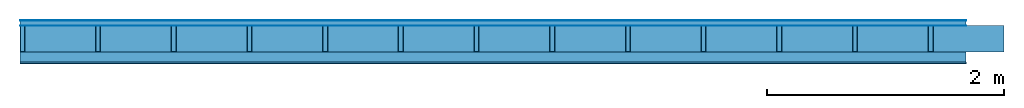
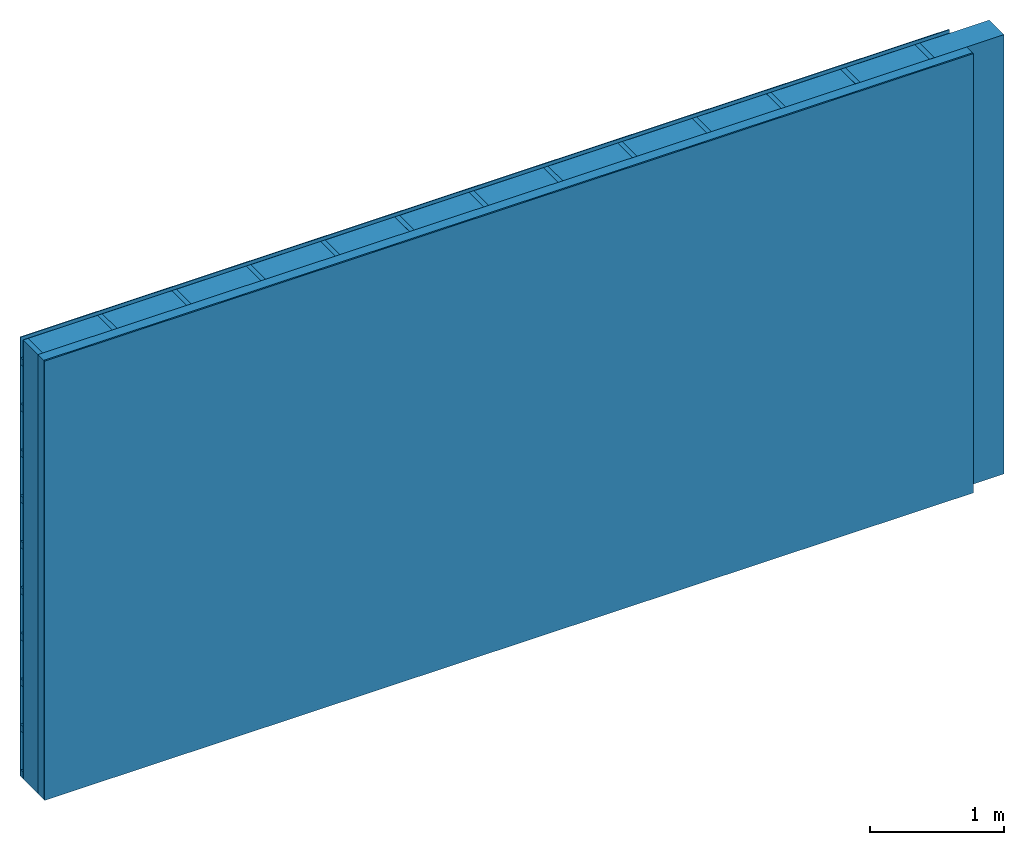
# One storey: 4 plates, 3 members, 1 element without a shape of its own.
"""IFC4 building model written with IfcOpenShell, lengths in metres."""

from ifc_helpers import new_model, si_unit, derived_unit, direction, frame, frame_2d, origin, origin_with_axes, place, context, project, spatial, rectangle, extrude, material, layer, layer_set, type_object, element, aggregate, save


model = new_model("IFC4")

# Units and contexts
plan_context = context("Plan", 3, precision=1e-05, world=origin(), true_north=direction((0.0, 1.0)))
model_context = context("Model", 3, precision=1e-05, world=origin(), true_north=direction((0.0, 1.0)))
ifc_project = project(units=[si_unit("LENGTHUNIT", "METRE"), derived_unit("SOUNDPRESSUREUNIT", [(si_unit("PRESSUREUNIT", "PASCAL", prefix="MICRO"), 0)]), si_unit("ENERGYUNIT", "JOULE", prefix="MEGA"), si_unit("MASSUNIT", "GRAM", prefix="KILO"), derived_unit("THERMALTRANSMITTANCEUNIT", [(si_unit("POWERUNIT", "WATT"), 1), (si_unit("AREAUNIT", "SQUARE_METRE"), -1), (si_unit("THERMODYNAMICTEMPERATUREUNIT", "KELVIN"), -1)]), derived_unit("AREADENSITYUNIT", [(si_unit("MASSUNIT", "GRAM", prefix="KILO"), 1), (si_unit("AREAUNIT", "SQUARE_METRE"), -1)]), derived_unit("USERDEFINED", [(si_unit("ENERGYUNIT", "JOULE", prefix="MEGA"), 1), (si_unit("AREAUNIT", "SQUARE_METRE"), -1)])], contexts=[plan_context, model_context])

# Site, building, storey
site = spatial("IfcSite", under=ifc_project)
building_placement = place(None, origin())
building = spatial("IfcBuilding", under=site, at=building_placement)
storey_placement = place(building_placement, origin())
storey = spatial("IfcBuildingStorey", under=building, at=storey_placement)

# Wall, members, plates
ifc_material_1 = material(Name="mineral, cement-based building board", Category="03.003")
ifc_layer_1 = layer(ifc_material_1, 0.008, Name="Cover 1st layer")
ifc_layer_2 = layer(None, 0.04, Name="Battens / profiles (ventilation)")
ifc_material_2 = material(Name="Vapor-permeable water barrier", Category="09.006")
ifc_layer_3 = layer(ifc_material_2, 0.0005, Name="outside 1st layer")
ifc_material_3 = material(Name="of the art")
ifc_layer_4 = layer(ifc_material_3, 0.0, Name="Bond")
ifc_layer_5 = layer(None, 0.22, Name="Support")
ifc_layer_6 = layer(ifc_material_3, 0.0, Name="Bond")
ifc_material_4 = material(Name="Solid timber panel")
ifc_layer_7 = layer(ifc_material_4, 0.087, Name="1st layer")
ifc_material_5 = material(Name="Plasterboard type A", Category="03.008")
ifc_layer_8 = layer(ifc_material_5, 0.0125, Name="Covering 1st layer")
ifc_material_6 = material(Name="joints", Category="04.017")
ifc_layer_9 = layer(ifc_material_6, 0.0, Name="Surface")
ifc_layer_set = layer_set([ifc_layer_1, ifc_layer_2, ifc_layer_3, ifc_layer_4, ifc_layer_5, ifc_layer_6, ifc_layer_7, ifc_layer_8, ifc_layer_9])
wall_type = type_object("IfcWallType", Name="D0996", PredefinedType="NOTDEFINED", material=ifc_layer_set)
wall_placement = place(None, frame((0.0, 0.0, 0.0), z_axis=(0.0, -1.0, 0.0), x_axis=(1.0, 0.0, 0.0)))
wall = element("IfcWall", 1, at=wall_placement, inside=storey, type_object=wall_type, material=ifc_layer_set, Name="Wall #1")
ifc_material_7 = material()
member_1_placement = place(wall_placement, origin())
member_1 = element("IfcMember", 2, at=member_1_placement, material=ifc_material_7, Name="Battens / profiles (ventilation)", context=plan_context, shape_type="SweptSolid", body=[
    extrude(rectangle(XDim=0.06, YDim=0.04, at=frame_2d((0.03, 0.02), x_axis=(1.0, 0.0))), frame((0.0, 0.0, 0.008), z_axis=(1.0, 0.0, 0.0), x_axis=(0.0, 1.0, 0.0)), (0.0, 0.0, 1.0), 8.0),
    extrude(rectangle(XDim=0.06, YDim=0.04, at=frame_2d((0.03, 0.02), x_axis=(1.0, 0.0))), frame((0.0, 0.417, 0.008), z_axis=(1.0, 0.0, 0.0), x_axis=(0.0, 1.0, 0.0)), (0.0, 0.0, 1.0), 8.0),
    extrude(rectangle(XDim=0.06, YDim=0.04, at=frame_2d((0.03, 0.02), x_axis=(1.0, 0.0))), frame((0.0, 0.834, 0.008), z_axis=(1.0, 0.0, 0.0), x_axis=(0.0, 1.0, 0.0)), (0.0, 0.0, 1.0), 8.0),
    extrude(rectangle(XDim=0.06, YDim=0.04, at=frame_2d((0.03, 0.02), x_axis=(1.0, 0.0))), frame((0.0, 1.251, 0.008), z_axis=(1.0, 0.0, 0.0), x_axis=(0.0, 1.0, 0.0)), (0.0, 0.0, 1.0), 8.0),
    extrude(rectangle(XDim=0.06, YDim=0.04, at=frame_2d((0.03, 0.02), x_axis=(1.0, 0.0))), frame((0.0, 1.668, 0.008), z_axis=(1.0, 0.0, 0.0), x_axis=(0.0, 1.0, 0.0)), (0.0, 0.0, 1.0), 8.0),
    extrude(rectangle(XDim=0.06, YDim=0.04, at=frame_2d((0.03, 0.02), x_axis=(1.0, 0.0))), frame((0.0, 2.085, 0.008), z_axis=(1.0, 0.0, 0.0), x_axis=(0.0, 1.0, 0.0)), (0.0, 0.0, 1.0), 8.0),
    extrude(rectangle(XDim=0.06, YDim=0.04, at=frame_2d((0.03, 0.02), x_axis=(1.0, 0.0))), frame((0.0, 2.502, 0.008), z_axis=(1.0, 0.0, 0.0), x_axis=(0.0, 1.0, 0.0)), (0.0, 0.0, 1.0), 8.0),
    extrude(rectangle(XDim=0.06, YDim=0.04, at=frame_2d((0.03, 0.02), x_axis=(1.0, 0.0))), frame((0.0, 2.919, 0.008), z_axis=(1.0, 0.0, 0.0), x_axis=(0.0, 1.0, 0.0)), (0.0, 0.0, 1.0), 8.0),
    extrude(rectangle(XDim=0.06, YDim=0.04, at=frame_2d((0.03, 0.02), x_axis=(1.0, 0.0))), frame((0.0, 3.336, 0.008), z_axis=(1.0, 0.0, 0.0), x_axis=(0.0, 1.0, 0.0)), (0.0, 0.0, 1.0), 8.0),
    extrude(rectangle(XDim=0.06, YDim=0.04, at=frame_2d((0.03, 0.02), x_axis=(1.0, 0.0))), frame((0.0, 3.753, 0.008), z_axis=(1.0, 0.0, 0.0), x_axis=(0.0, 1.0, 0.0)), (0.0, 0.0, 1.0), 8.0),
])
ifc_material_8 = material()
member_2_placement = place(wall_placement, origin())
member_2 = element("IfcMember", 3, at=member_2_placement, material=ifc_material_8, Name="Support", context=plan_context, shape_type="SweptSolid", body=[
    extrude(rectangle(XDim=0.04, YDim=0.22, at=frame_2d((0.02, 0.11), x_axis=(1.0, 0.0))), frame((0.0, 4.0, 0.0485), z_axis=(0.0, -1.0, 0.0), x_axis=(1.0, 0.0, 0.0)), (0.0, 0.0, 1.0), 4.0),
    extrude(rectangle(XDim=0.04, YDim=0.22, at=frame_2d((0.02, 0.11), x_axis=(1.0, 0.0))), frame((0.64, 4.0, 0.0485), z_axis=(0.0, -1.0, 0.0), x_axis=(1.0, 0.0, 0.0)), (0.0, 0.0, 1.0), 4.0),
    extrude(rectangle(XDim=0.04, YDim=0.22, at=frame_2d((0.02, 0.11), x_axis=(1.0, 0.0))), frame((1.28, 4.0, 0.0485), z_axis=(0.0, -1.0, 0.0), x_axis=(1.0, 0.0, 0.0)), (0.0, 0.0, 1.0), 4.0),
    extrude(rectangle(XDim=0.04, YDim=0.22, at=frame_2d((0.02, 0.11), x_axis=(1.0, 0.0))), frame((1.92, 4.0, 0.0485), z_axis=(0.0, -1.0, 0.0), x_axis=(1.0, 0.0, 0.0)), (0.0, 0.0, 1.0), 4.0),
    extrude(rectangle(XDim=0.04, YDim=0.22, at=frame_2d((0.02, 0.11), x_axis=(1.0, 0.0))), frame((2.56, 4.0, 0.0485), z_axis=(0.0, -1.0, 0.0), x_axis=(1.0, 0.0, 0.0)), (0.0, 0.0, 1.0), 4.0),
    extrude(rectangle(XDim=0.04, YDim=0.22, at=frame_2d((0.02, 0.11), x_axis=(1.0, 0.0))), frame((3.2, 4.0, 0.0485), z_axis=(0.0, -1.0, 0.0), x_axis=(1.0, 0.0, 0.0)), (0.0, 0.0, 1.0), 4.0),
    extrude(rectangle(XDim=0.04, YDim=0.22, at=frame_2d((0.02, 0.11), x_axis=(1.0, 0.0))), frame((3.84, 4.0, 0.0485), z_axis=(0.0, -1.0, 0.0), x_axis=(1.0, 0.0, 0.0)), (0.0, 0.0, 1.0), 4.0),
    extrude(rectangle(XDim=0.04, YDim=0.22, at=frame_2d((0.02, 0.11), x_axis=(1.0, 0.0))), frame((4.48, 4.0, 0.0485), z_axis=(0.0, -1.0, 0.0), x_axis=(1.0, 0.0, 0.0)), (0.0, 0.0, 1.0), 4.0),
    extrude(rectangle(XDim=0.04, YDim=0.22, at=frame_2d((0.02, 0.11), x_axis=(1.0, 0.0))), frame((5.12, 4.0, 0.0485), z_axis=(0.0, -1.0, 0.0), x_axis=(1.0, 0.0, 0.0)), (0.0, 0.0, 1.0), 4.0),
    extrude(rectangle(XDim=0.04, YDim=0.22, at=frame_2d((0.02, 0.11), x_axis=(1.0, 0.0))), frame((5.76, 4.0, 0.0485), z_axis=(0.0, -1.0, 0.0), x_axis=(1.0, 0.0, 0.0)), (0.0, 0.0, 1.0), 4.0),
    extrude(rectangle(XDim=0.04, YDim=0.22, at=frame_2d((0.02, 0.11), x_axis=(1.0, 0.0))), frame((6.4, 4.0, 0.0485), z_axis=(0.0, -1.0, 0.0), x_axis=(1.0, 0.0, 0.0)), (0.0, 0.0, 1.0), 4.0),
    extrude(rectangle(XDim=0.04, YDim=0.22, at=frame_2d((0.02, 0.11), x_axis=(1.0, 0.0))), frame((7.04, 4.0, 0.0485), z_axis=(0.0, -1.0, 0.0), x_axis=(1.0, 0.0, 0.0)), (0.0, 0.0, 1.0), 4.0),
    extrude(rectangle(XDim=0.04, YDim=0.22, at=frame_2d((0.02, 0.11), x_axis=(1.0, 0.0))), frame((7.68, 4.0, 0.0485), z_axis=(0.0, -1.0, 0.0), x_axis=(1.0, 0.0, 0.0)), (0.0, 0.0, 1.0), 4.0),
])
ifc_material_9 = material(Name="Mineral wool")
member_3_placement = place(wall_placement, origin())
member_3 = element("IfcMember", 4, at=member_3_placement, material=ifc_material_9, Name="Cavity", context=plan_context, shape_type="SweptSolid", body=[
    extrude(rectangle(XDim=0.6, YDim=0.22, at=frame_2d((0.3, 0.11), x_axis=(1.0, 0.0))), frame((0.04, 4.0, 0.0485), z_axis=(0.0, -1.0, 0.0), x_axis=(1.0, 0.0, 0.0)), (0.0, 0.0, 1.0), 4.0),
    extrude(rectangle(XDim=0.6, YDim=0.22, at=frame_2d((0.3, 0.11), x_axis=(1.0, 0.0))), frame((0.68, 4.0, 0.0485), z_axis=(0.0, -1.0, 0.0), x_axis=(1.0, 0.0, 0.0)), (0.0, 0.0, 1.0), 4.0),
    extrude(rectangle(XDim=0.6, YDim=0.22, at=frame_2d((0.3, 0.11), x_axis=(1.0, 0.0))), frame((1.32, 4.0, 0.0485), z_axis=(0.0, -1.0, 0.0), x_axis=(1.0, 0.0, 0.0)), (0.0, 0.0, 1.0), 4.0),
    extrude(rectangle(XDim=0.6, YDim=0.22, at=frame_2d((0.3, 0.11), x_axis=(1.0, 0.0))), frame((1.96, 4.0, 0.0485), z_axis=(0.0, -1.0, 0.0), x_axis=(1.0, 0.0, 0.0)), (0.0, 0.0, 1.0), 4.0),
    extrude(rectangle(XDim=0.6, YDim=0.22, at=frame_2d((0.3, 0.11), x_axis=(1.0, 0.0))), frame((2.6, 4.0, 0.0485), z_axis=(0.0, -1.0, 0.0), x_axis=(1.0, 0.0, 0.0)), (0.0, 0.0, 1.0), 4.0),
    extrude(rectangle(XDim=0.6, YDim=0.22, at=frame_2d((0.3, 0.11), x_axis=(1.0, 0.0))), frame((3.24, 4.0, 0.0485), z_axis=(0.0, -1.0, 0.0), x_axis=(1.0, 0.0, 0.0)), (0.0, 0.0, 1.0), 4.0),
    extrude(rectangle(XDim=0.6, YDim=0.22, at=frame_2d((0.3, 0.11), x_axis=(1.0, 0.0))), frame((3.88, 4.0, 0.0485), z_axis=(0.0, -1.0, 0.0), x_axis=(1.0, 0.0, 0.0)), (0.0, 0.0, 1.0), 4.0),
    extrude(rectangle(XDim=0.6, YDim=0.22, at=frame_2d((0.3, 0.11), x_axis=(1.0, 0.0))), frame((4.52, 4.0, 0.0485), z_axis=(0.0, -1.0, 0.0), x_axis=(1.0, 0.0, 0.0)), (0.0, 0.0, 1.0), 4.0),
    extrude(rectangle(XDim=0.6, YDim=0.22, at=frame_2d((0.3, 0.11), x_axis=(1.0, 0.0))), frame((5.16, 4.0, 0.0485), z_axis=(0.0, -1.0, 0.0), x_axis=(1.0, 0.0, 0.0)), (0.0, 0.0, 1.0), 4.0),
    extrude(rectangle(XDim=0.6, YDim=0.22, at=frame_2d((0.3, 0.11), x_axis=(1.0, 0.0))), frame((5.8, 4.0, 0.0485), z_axis=(0.0, -1.0, 0.0), x_axis=(1.0, 0.0, 0.0)), (0.0, 0.0, 1.0), 4.0),
    extrude(rectangle(XDim=0.6, YDim=0.22, at=frame_2d((0.3, 0.11), x_axis=(1.0, 0.0))), frame((6.44, 4.0, 0.0485), z_axis=(0.0, -1.0, 0.0), x_axis=(1.0, 0.0, 0.0)), (0.0, 0.0, 1.0), 4.0),
    extrude(rectangle(XDim=0.6, YDim=0.22, at=frame_2d((0.3, 0.11), x_axis=(1.0, 0.0))), frame((7.08, 4.0, 0.0485), z_axis=(0.0, -1.0, 0.0), x_axis=(1.0, 0.0, 0.0)), (0.0, 0.0, 1.0), 4.0),
    extrude(rectangle(XDim=0.6, YDim=0.22, at=frame_2d((0.3, 0.11), x_axis=(1.0, 0.0))), frame((7.72, 4.0, 0.0485), z_axis=(0.0, -1.0, 0.0), x_axis=(1.0, 0.0, 0.0)), (0.0, 0.0, 1.0), 4.0),
])
plate_1_placement = place(wall_placement, origin())
plate_1 = element("IfcPlate", 5, at=plate_1_placement, material=ifc_material_1, Name="Cover 1st layer", context=plan_context, shape_type="SweptSolid", body=[
    extrude(rectangle(XDim=8.0, YDim=4.0, at=frame_2d((4.0, 2.0), x_axis=(1.0, 0.0))), origin_with_axes(), (0.0, 0.0, 1.0), 0.008),
])
plate_2_placement = place(wall_placement, origin())
plate_2 = element("IfcPlate", 6, at=plate_2_placement, material=ifc_material_2, Name="outside 1st layer", context=plan_context, shape_type="SweptSolid", body=[
    extrude(rectangle(XDim=8.0, YDim=4.0, at=frame_2d((4.0, 2.0), x_axis=(1.0, 0.0))), frame((0.0, 0.0, 0.048), z_axis=(0.0, 0.0, 1.0), x_axis=(1.0, 0.0, 0.0)), (0.0, 0.0, 1.0), 0.0005),
])
plate_3_placement = place(wall_placement, origin())
plate_3 = element("IfcPlate", 7, at=plate_3_placement, material=ifc_material_4, Name="1st layer", context=plan_context, shape_type="SweptSolid", body=[
    extrude(rectangle(XDim=8.0, YDim=4.0, at=frame_2d((4.0, 2.0), x_axis=(1.0, 0.0))), frame((0.0, 0.0, 0.2685), z_axis=(0.0, 0.0, 1.0), x_axis=(1.0, 0.0, 0.0)), (0.0, 0.0, 1.0), 0.087),
])
plate_4_placement = place(wall_placement, origin())
plate_4 = element("IfcPlate", 8, at=plate_4_placement, material=ifc_material_5, Name="Covering 1st layer", context=plan_context, shape_type="SweptSolid", body=[
    extrude(rectangle(XDim=8.0, YDim=4.0, at=frame_2d((4.0, 2.0), x_axis=(1.0, 0.0))), frame((0.0, 0.0, 0.3555), z_axis=(0.0, 0.0, 1.0), x_axis=(1.0, 0.0, 0.0)), (0.0, 0.0, 1.0), 0.0125),
])
aggregate(wall, [plate_1, member_1, plate_2, member_2, member_3, plate_3, plate_4])

save(model, "model.ifc")
